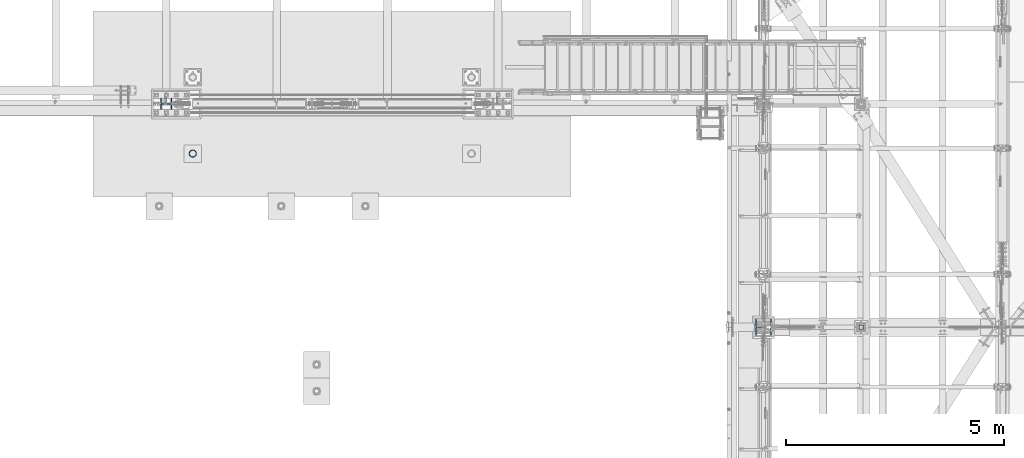
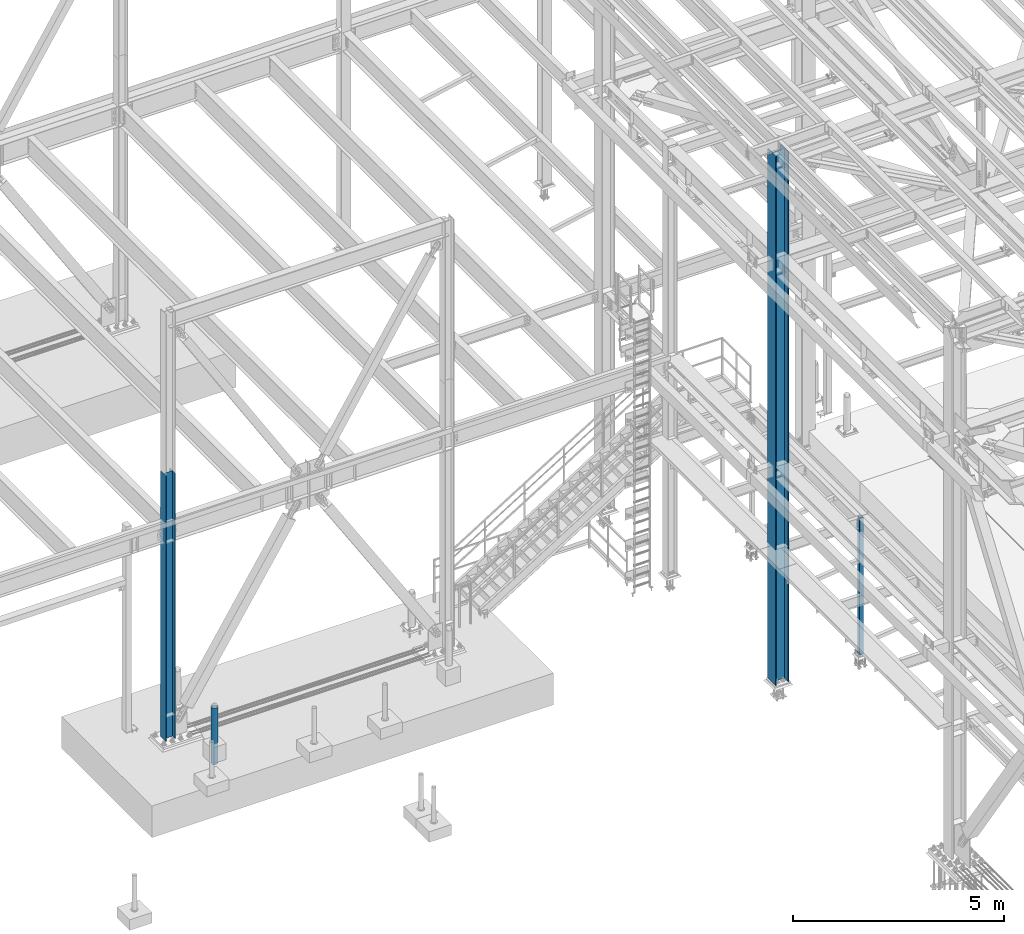
# One storey, part 1363 of 3843: 4 columns, 4 elements without a shape of their own.
"""IFC2X3 building model written with IfcOpenShell, lengths in millimetres."""

from ifc_helpers import new_model, si_unit, frame, origin_with_axes, place, context, subcontext, project, spatial, faceted_brep, material, type_object, element, aggregate, save


model = new_model("IFC2X3")

# Units and contexts
model_context = context("Model", 3, precision=1e-05, world=origin_with_axes())
body_context = subcontext(model_context, "Body", "Model", "MODEL_VIEW")
ifc_project = project(units=[si_unit("LENGTHUNIT", "METRE", prefix="MILLI"), si_unit("AREAUNIT", "SQUARE_METRE"), si_unit("VOLUMEUNIT", "CUBIC_METRE"), si_unit("MASSUNIT", "GRAM", prefix="KILO"), si_unit("TIMEUNIT", "SECOND"), si_unit("PLANEANGLEUNIT", "RADIAN"), si_unit("SOLIDANGLEUNIT", "STERADIAN"), si_unit("THERMODYNAMICTEMPERATUREUNIT", "DEGREE_CELSIUS"), si_unit("LUMINOUSINTENSITYUNIT", "LUMEN")], contexts=[model_context])

# Site, building, storey
site_placement = place(None, origin_with_axes())
site = spatial("IfcSite", under=ifc_project, at=site_placement, CompositionType="ELEMENT")
building_placement = place(site_placement, origin_with_axes())
building = spatial("IfcBuilding", under=site, at=building_placement, Name="Undefined", CompositionType="ELEMENT")
storey_placement = place(building_placement, origin_with_axes())
storey = spatial("IfcBuildingStorey", under=building, at=storey_placement, Name="Undefined", CompositionType="ELEMENT", Elevation=0.0)

# Assembly, column
assembly_1_placement = place(storey_placement, origin_with_axes())
assembly_1 = element("IfcElementAssembly", 1, at=assembly_1_placement, inside=storey, Name="PIPE_BOLLARD", AssemblyPlace="NOTDEFINED", PredefinedType="RIGID_FRAME")
ifc_material_1 = material()
column_type_1 = type_object("IfcColumnType", Name="PIPE6SCH40", PredefinedType="NOTDEFINED")
column_1_placement = place(assembly_1_placement, frame((23469.6, 87972.9, 29870.4), z_axis=(-1.0, 0.0, 0.0), x_axis=(0.0, 0.0, 1.0)))
column_1 = element("IfcColumn", 2, at=column_1_placement, type_object=column_type_1, material=ifc_material_1, Name="PIPE_BOLLARD", ObjectType="PIPE6SCH40", context=body_context, shape_type="Brep", body=[
    faceted_brep([(0.0, -77.0890000000072, 0.0), (0.0, -74.4622560228017, 19.9521013679077), (1625.6, -74.4622560228017, 19.9521013679077), (1625.6, -77.0890000000072, 0.0), (0.0, -66.7610323523404, 38.5445), (1625.6, -66.7610323523404, 38.5445), (0.0, -54.5101546548831, 54.5101546548904), (1625.6, -54.5101546548831, 54.5101546548904), (0.0, -38.5445000000036, 66.7610323523386), (1625.6, -38.5445000000036, 66.7610323523386), (0.0, -19.9521013679041, 74.4622560227981), (1625.6, -19.9521013679041, 74.4622560227981), (0.0, 0.0, 77.0889999999999), (1625.6, 0.0, 77.0889999999999), (0.0, 19.9521013679041, 74.4622560227981), (1625.6, 19.9521013679041, 74.4622560227981), (0.0, 38.5445000000036, 66.7610323523386), (1625.6, 38.5445000000036, 66.7610323523386), (0.0, 54.5101546548831, 54.5101546548904), (1625.6, 54.5101546548831, 54.5101546548904), (0.0, 66.7610323523404, 38.5445), (1625.6, 66.7610323523404, 38.5445), (0.0, 74.4622560228017, 19.9521013679077), (1625.6, 74.4622560228017, 19.9521013679077), (0.0, 77.0890000000072, 0.0), (1625.6, 77.0890000000072, 0.0), (0.0, 74.4622560228017, -19.9521013679077), (1625.6, 74.4622560228017, -19.9521013679077), (0.0, 66.7610323523404, -38.5445), (1625.6, 66.7610323523404, -38.5445), (0.0, 54.5101546548831, -54.5101546548904), (1625.6, 54.5101546548831, -54.5101546548904), (0.0, 38.5445000000036, -66.7610323523386), (1625.6, 38.5445000000036, -66.7610323523386), (0.0, 19.9521013679041, -74.4622560227981), (1625.6, 19.9521013679041, -74.4622560227981), (0.0, 0.0, -77.0889999999999), (1625.6, 0.0, -77.0889999999999), (0.0, -19.9521013679041, -74.4622560227981), (1625.6, -19.9521013679041, -74.4622560227981), (0.0, -38.5445000000036, -66.7610323523386), (1625.6, -38.5445000000036, -66.7610323523386), (0.0, -54.5101546548831, -54.5101546548904), (1625.6, -54.5101546548831, -54.5101546548904), (0.0, -66.7610323523404, -38.5445), (1625.6, -66.7610323523404, -38.5445), (0.0, -74.4622560228017, -19.9521013679077), (1625.6, -74.4622560228017, -19.9521013679077), (0.0, -84.2010000000009, 0.0), (0.0, -81.3319204993604, -21.7928224166772), (1625.6, -81.3319204993604, -21.7928224166772), (1625.6, -84.2010000000009, 0.0), (0.0, -72.9202050240565, -42.1005000000005), (1625.6, -72.9202050240565, -42.1005000000005), (0.0, -59.5390980826924, -59.5390980826887), (1625.6, -59.5390980826924, -59.5390980826887), (0.0, -42.1005000000005, -72.9202050240528), (1625.6, -42.1005000000005, -72.9202050240528), (0.0, -21.7928224166826, -81.3319204993659), (1625.6, -21.7928224166826, -81.3319204993659), (0.0, 0.0, -84.2009999999991), (1625.6, 0.0, -84.2009999999991), (0.0, 21.7928224166826, -81.3319204993659), (1625.6, 21.7928224166826, -81.3319204993659), (0.0, 42.1005000000005, -72.9202050240528), (1625.6, 42.1005000000005, -72.9202050240528), (0.0, 59.5390980826924, -59.5390980826887), (1625.6, 59.5390980826924, -59.5390980826887), (0.0, 72.9202050240565, -42.1005000000005), (1625.6, 72.9202050240565, -42.1005000000005), (0.0, 81.3319204993604, -21.7928224166772), (1625.6, 81.3319204993604, -21.7928224166772), (0.0, 84.2010000000009, 0.0), (1625.6, 84.2010000000009, 0.0), (0.0, 81.3319204993604, 21.7928224166772), (1625.6, 81.3319204993604, 21.7928224166772), (0.0, 72.9202050240565, 42.1005000000005), (1625.6, 72.9202050240565, 42.1005000000005), (0.0, 59.5390980826924, 59.5390980826887), (1625.6, 59.5390980826924, 59.5390980826887), (0.0, 42.1005000000005, 72.9202050240528), (1625.6, 42.1005000000005, 72.9202050240528), (0.0, 21.7928224166826, 81.3319204993659), (1625.6, 21.7928224166826, 81.3319204993659), (0.0, 0.0, 84.2009999999991), (1625.6, 0.0, 84.2009999999991), (0.0, -21.7928224166826, 81.3319204993659), (1625.6, -21.7928224166826, 81.3319204993659), (0.0, -42.1005000000005, 72.9202050240528), (1625.6, -42.1005000000005, 72.9202050240528), (0.0, -59.5390980826924, 59.5390980826887), (1625.6, -59.5390980826924, 59.5390980826887), (0.0, -72.9202050240565, 42.1005000000005), (1625.6, -72.9202050240565, 42.1005000000005), (0.0, -81.3319204993604, 21.7928224166772), (1625.6, -81.3319204993604, 21.7928224166772)], [[[0, 1, 2, 3]], [[1, 4, 5, 2]], [[4, 6, 7, 5]], [[6, 8, 9, 7]], [[8, 10, 11, 9]], [[10, 12, 13, 11]], [[12, 14, 15, 13]], [[14, 16, 17, 15]], [[16, 18, 19, 17]], [[18, 20, 21, 19]], [[20, 22, 23, 21]], [[22, 24, 25, 23]], [[24, 26, 27, 25]], [[26, 28, 29, 27]], [[28, 30, 31, 29]], [[30, 32, 33, 31]], [[32, 34, 35, 33]], [[34, 36, 37, 35]], [[36, 38, 39, 37]], [[38, 40, 41, 39]], [[40, 42, 43, 41]], [[42, 44, 45, 43]], [[44, 46, 47, 45]], [[46, 0, 3, 47]], [[48, 49, 50, 51]], [[49, 52, 53, 50]], [[52, 54, 55, 53]], [[54, 56, 57, 55]], [[56, 58, 59, 57]], [[58, 60, 61, 59]], [[60, 62, 63, 61]], [[62, 64, 65, 63]], [[64, 66, 67, 65]], [[66, 68, 69, 67]], [[68, 70, 71, 69]], [[70, 72, 73, 71]], [[72, 74, 75, 73]], [[74, 76, 77, 75]], [[76, 78, 79, 77]], [[78, 80, 81, 79]], [[80, 82, 83, 81]], [[82, 84, 85, 83]], [[84, 86, 87, 85]], [[86, 88, 89, 87]], [[88, 90, 91, 89]], [[90, 92, 93, 91]], [[92, 94, 95, 93]], [[94, 48, 51, 95]], [[53, 55, 57, 59, 61, 63, 65, 67, 69, 71, 73, 75, 77, 79, 81, 83, 85, 87, 89, 91, 93, 95, 51, 50], [5, 7, 9, 11, 13, 15, 17, 19, 21, 23, 25, 27, 29, 31, 33, 35, 37, 39, 41, 43, 45, 47, 3, 2]], [[94, 92, 90, 88, 86, 84, 82, 80, 78, 76, 74, 72, 70, 68, 66, 64, 62, 60, 58, 56, 54, 52, 49, 48], [46, 44, 42, 40, 38, 36, 34, 32, 30, 28, 26, 24, 22, 20, 18, 16, 14, 12, 10, 8, 6, 4, 1, 0]]]),
])
aggregate(assembly_1, [column_1])

assembly_2_placement = place(storey_placement, origin_with_axes())
assembly_2 = element("IfcElementAssembly", 3, at=assembly_2_placement, inside=storey, Name="COLUMN", AssemblyPlace="NOTDEFINED", PredefinedType="RIGID_FRAME")
ifc_material_2 = material()
column_type_2 = type_object("IfcColumnType", Name="HSS4X4X3/8", PredefinedType="NOTDEFINED")
column_2_placement = place(assembly_2_placement, frame((38820.725, 83985.1, 30022.8), z_axis=(-1.0, 0.0, 0.0), x_axis=(0.0, 0.0, 1.0)))
column_2 = element("IfcColumn", 4, at=column_2_placement, type_object=column_type_2, material=ifc_material_2, Name="COLUMN", ObjectType="HSS4X4X3/8", context=body_context, shape_type="Brep", body=[
    faceted_brep([(57.1500000000015, 41.2749999999942, -41.2750000000015), (57.1500000000015, -41.2749999999942, -41.2750000000015), (4000.5, -41.2749999999942, -41.2750000000015), (4000.5, 41.2749999999942, -41.2750000000015), (57.1500000000015, -41.2749999999942, 41.2750000000015), (4000.5, -41.2749999999942, 41.2750000000015), (57.1500000000015, 41.2749999999942, 41.2750000000015), (4000.5, 41.2749999999942, 41.2750000000015), (57.1500000000015, 50.8000000000029, -50.8000000000029), (57.1500000000015, 50.8000000000029, 50.8000000000029), (4000.5, 50.8000000000029, 50.8000000000029), (4000.5, 50.8000000000029, -50.8000000000029), (57.1500000000015, -50.8000000000029, 50.8000000000029), (4000.5, -50.8000000000029, 50.8000000000029), (57.1500000000015, -50.8000000000029, -50.8000000000029), (4000.5, -50.8000000000029, -50.8000000000029)], [[[0, 1, 2, 3]], [[1, 4, 5, 2]], [[4, 6, 7, 5]], [[6, 0, 3, 7]], [[8, 9, 10, 11]], [[9, 12, 13, 10]], [[12, 14, 15, 13]], [[14, 8, 11, 15]], [[13, 15, 11, 10], [5, 7, 3, 2]], [[14, 12, 9, 8], [6, 4, 1, 0]]]),
])
aggregate(assembly_2, [column_2])

assembly_3_placement = place(storey_placement, origin_with_axes())
assembly_3 = element("IfcElementAssembly", 5, at=assembly_3_placement, inside=storey, Name="COLUMN", AssemblyPlace="NOTDEFINED", PredefinedType="RIGID_FRAME")
ifc_material_3 = material(Name="STEEL/A992")
column_type_3 = type_object("IfcColumnType", Name="W10X60", PredefinedType="NOTDEFINED")
column_3_placement = place(assembly_3_placement, frame((22860.0, 89115.9, 30022.8), z_axis=(-1.0, 0.0, 0.0), x_axis=(0.0, 0.0, 1.0)))
column_3 = element("IfcColumn", 6, at=column_3_placement, type_object=column_type_3, material=ifc_material_3, Name="COLUMN", ObjectType="W10X60", context=body_context, shape_type="Brep", body=[
    faceted_brep([(101.599999999999, 128.587499999994, -130.174999999999), (101.599999999999, 128.587499999994, -112.712500000001), (7772.4, 128.587499999994, -112.712500000001), (7772.4, 128.587499999994, -130.174999999999), (101.599999999999, 5.55624999999418, -112.712500000001), (7772.4, 5.55624999999418, -112.712500000001), (101.599999999999, 5.55624999999418, 112.712500000001), (7772.4, 5.55624999999418, 112.712500000001), (101.599999999999, 128.587499999994, 112.712500000001), (7772.4, 128.587499999994, 112.712500000001), (101.599999999999, 128.587499999994, 130.174999999999), (7772.4, 128.587499999994, 130.174999999999), (101.599999999999, -128.587499999994, 130.174999999999), (7772.4, -128.587499999994, 130.174999999999), (101.599999999999, -128.587499999994, 112.712500000001), (7772.4, -128.587499999994, 112.712500000001), (101.599999999999, -5.55624999999418, 112.712500000001), (7772.4, -5.55624999999418, 112.712500000001), (101.599999999999, -5.55624999999418, -112.712500000001), (7772.4, -5.55624999999418, -112.712500000001), (101.599999999999, -128.587499999994, -112.712500000001), (7772.4, -128.587499999994, -112.712500000001), (101.599999999999, -128.587499999994, -130.174999999999), (7772.4, -128.587499999994, -130.174999999999)], [[[0, 1, 2, 3]], [[1, 4, 5, 2]], [[4, 6, 7, 5]], [[6, 8, 9, 7]], [[8, 10, 11, 9]], [[10, 12, 13, 11]], [[12, 14, 15, 13]], [[14, 16, 17, 15]], [[16, 18, 19, 17]], [[18, 20, 21, 19]], [[20, 22, 23, 21]], [[22, 0, 3, 23]], [[5, 7, 9, 11, 13, 15, 17, 19, 21, 23, 3, 2]], [[22, 20, 18, 16, 14, 12, 10, 8, 6, 4, 1, 0]]]),
])
aggregate(assembly_3, [column_3])

assembly_4_placement = place(storey_placement, origin_with_axes())
assembly_4 = element("IfcElementAssembly", 7, at=assembly_4_placement, inside=storey, Name="COLUMN", AssemblyPlace="NOTDEFINED", PredefinedType="RIGID_FRAME")
column_type_4 = type_object("IfcColumnType", Name="W14X120", PredefinedType="NOTDEFINED")
column_4_placement = place(assembly_4_placement, frame((36576.0, 83985.1, 30022.8), z_axis=(-1.0, 0.0, 0.0), x_axis=(0.0, 0.0, 1.0)))
column_4 = element("IfcColumn", 8, at=column_4_placement, type_object=column_type_4, material=ifc_material_3, Name="COLUMN", ObjectType="W14X120", context=body_context, shape_type="Brep", body=[
    faceted_brep([(76.200000000008, -185.737500000003, -184.150000000001), (76.200000000008, -185.737500000003, -160.337500000001), (76.200000000008, -7.14375000000291, -160.337500000001), (76.200000000008, -7.14375000000291, 160.337500000001), (76.200000000008, -185.737500000003, 160.337500000001), (76.200000000008, -185.737500000003, 184.150000000001), (76.200000000008, 185.737500000003, 184.150000000001), (76.200000000008, 185.737500000003, 160.337500000001), (76.200000000008, 7.14375000000291, 160.337500000001), (76.200000000008, 7.14375000000291, -160.337500000001), (76.200000000008, 185.737500000003, -160.337500000001), (76.200000000008, 185.737500000003, -184.150000000001), (15375.8004169701, -185.737500000003, 184.150000000001), (15375.8004169701, 185.737500000003, 184.150000000001), (15375.8004169701, 185.737500000003, 160.337500000001), (15375.8004169701, 7.14375000000291, 160.337500000001), (15375.8004169701, 7.14375000000291, -160.337500000001), (15375.8004169701, 185.737500000003, -160.337500000001), (15375.8004169701, 185.737500000003, -184.150000000001), (15375.8004169701, -185.737500000003, -184.150000000001), (15375.8004169701, -185.737500000003, -160.337500000001), (15375.8004169701, -7.14375000000291, -160.337500000001), (15375.8004169701, -7.14375000000291, 160.337500000001), (15375.8004169701, -185.737500000003, 160.337500000001)], [[[0, 1, 2, 3, 4, 5, 6, 7, 8, 9, 10, 11]], [[6, 5, 12, 13]], [[7, 6, 13, 14]], [[8, 7, 14, 15]], [[9, 8, 15, 16]], [[10, 9, 16, 17]], [[11, 10, 17, 18]], [[0, 11, 18, 19]], [[1, 0, 19, 20]], [[2, 1, 20, 21]], [[3, 2, 21, 22]], [[4, 3, 22, 23]], [[5, 4, 23, 12]], [[22, 21, 20, 19, 18, 17, 16, 15, 14, 13, 12, 23]]]),
])
aggregate(assembly_4, [column_4])

save(model, "model.ifc")
